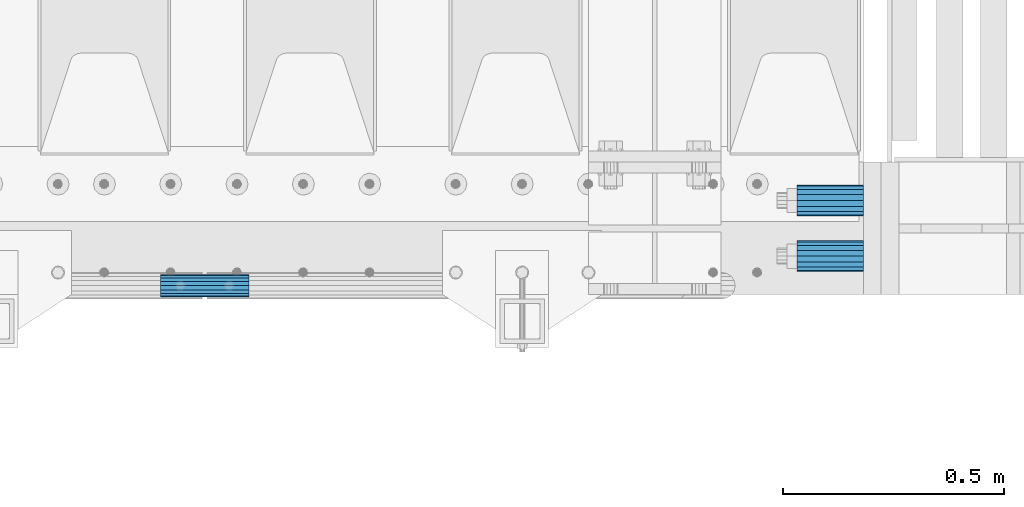
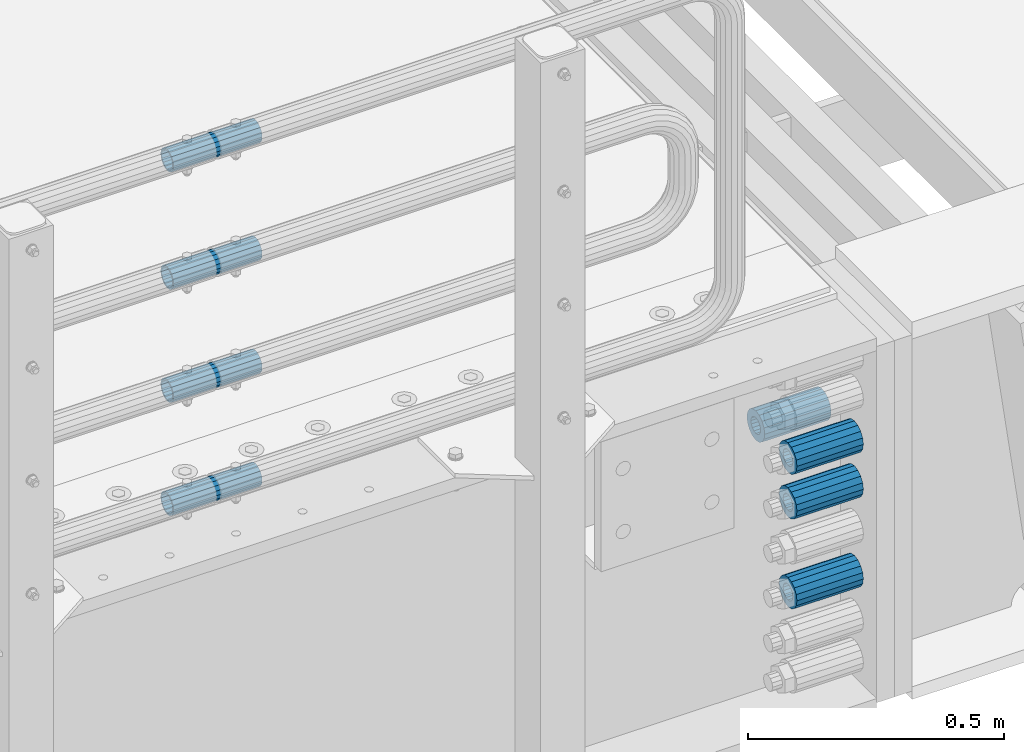
# One storey, part 157 of 247: 8 beams.
"""IFC2X3 building model written with IfcOpenShell, lengths in millimetres."""

from ifc_helpers import new_model, si_unit, frame, origin_with_axes, place, context, subcontext, project, spatial, faceted_brep, material, type_object, element, save


model = new_model("IFC2X3")

# Units and contexts
model_context = context("Model", 3, precision=1e-05, world=origin_with_axes())
body_context = subcontext(model_context, "Body", "Model", "MODEL_VIEW")
ifc_project = project(units=[si_unit("LENGTHUNIT", "METRE", prefix="MILLI"), si_unit("AREAUNIT", "SQUARE_METRE"), si_unit("VOLUMEUNIT", "CUBIC_METRE"), si_unit("MASSUNIT", "GRAM", prefix="KILO"), si_unit("TIMEUNIT", "SECOND"), si_unit("PLANEANGLEUNIT", "RADIAN"), si_unit("SOLIDANGLEUNIT", "STERADIAN"), si_unit("THERMODYNAMICTEMPERATUREUNIT", "DEGREE_CELSIUS"), si_unit("LUMINOUSINTENSITYUNIT", "LUMEN")], contexts=[model_context])

# Site, building, storey
site_placement = place(None, origin_with_axes())
site = spatial("IfcSite", under=ifc_project, at=site_placement, CompositionType="ELEMENT")
building_placement = place(site_placement, origin_with_axes())
building = spatial("IfcBuilding", under=site, at=building_placement, Name="Standard", CompositionType="ELEMENT")
storey_placement = place(building_placement, origin_with_axes())
storey = spatial("IfcBuildingStorey", under=building, at=storey_placement, Name="Undefined", CompositionType="ELEMENT", Elevation=0.0)

# Beams
ifc_material = material()
beam_type_1 = type_object("IfcBeamType", PredefinedType="NOTDEFINED")
beam_1_placement = place(storey_placement, frame((16667.0, 63.0, -285.0), z_axis=(0.0, 0.0, 1.0), x_axis=(1.0, 0.0, 0.0)))
element("IfcBeam", 1, at=beam_1_placement, inside=storey, type_object=beam_type_1, material=ifc_material, context=body_context, shape_type="Brep", body=[
    faceted_brep([(-1.3120632047503e-07, -18.9999999995497, -6.27005647402257e-09), (0.0, -17.5537111177146, 7.27098521493672), (150.0, -17.5537111177146, 7.27098521493672), (150.0, -19.0, 0.0), (0.0, -13.4350288425444, 13.4350288425444), (150.0, -13.4350288425444, 13.4350288425444), (0.0, -7.2709852149369, 17.5537111177144), (150.0, -7.2709852149369, 17.5537111177144), (-6.3396328187082e-09, 4.50427251053043e-10, 18.9999999937299), (150.0, 0.0, 19.0), (0.0, 7.2709852149369, 17.5537111177144), (150.0, 7.2709852149369, 17.5537111177144), (0.0, 13.4350288425444, 13.4350288425444), (150.0, 13.4350288425444, 13.4350288425444), (0.0, 17.5537111177146, 7.2709852149367), (150.0, 17.5537111177146, 7.2709852149367), (1.33208573060983e-07, 19.0000000004504, -6.27005647402257e-09), (150.0, 19.0, 0.0), (0.0, 17.5537111177146, -7.2709852149367), (150.0, 17.5537111177146, -7.2709852149367), (0.0, 13.4350288425444, -13.4350288425444), (150.0, 13.4350288425444, -13.4350288425444), (0.0, 7.2709852149369, -17.5537111177144), (150.0, 7.2709852149369, -17.5537111177144), (8.3418854046613e-09, 4.50427251053043e-10, -19.0000000062682), (150.0, 0.0, -19.0), (0.0, -7.2709852149369, -17.5537111177144), (150.0, -7.2709852149369, -17.5537111177144), (0.0, -13.4350288425444, -13.4350288425444), (150.0, -13.4350288425444, -13.4350288425444), (0.0, -17.5537111177146, -7.2709852149367), (150.0, -17.5537111177146, -7.2709852149367), (0.0, -35.0, 0.0), (0.0, -32.335783637895, -13.3939201327782), (150.0, -32.335783637895, -13.3939201327782), (150.0, -35.0, 0.0), (0.0, -24.7487373415292, -24.7487373415291), (150.0, -24.7487373415293, -24.7487373415292), (0.0, -13.3939201327781, -32.335783637895), (150.0, -13.393920132778, -32.335783637895), (0.0, 0.0, -35.0000000000001), (150.0, 0.0, -35.0), (0.0, 13.3939201327782, -32.335783637895), (150.0, 13.393920132778, -32.335783637895), (0.0, 24.7487373415292, -24.7487373415291), (150.0, 24.7487373415293, -24.7487373415292), (0.0, 32.335783637895, -13.3939201327782), (150.0, 32.335783637895, -13.3939201327781), (0.0, 35.0, 0.0), (150.0, 35.0, 0.0), (0.0, 32.335783637895, 13.3939201327781), (150.0, 32.335783637895, 13.3939201327781), (0.0, 24.7487373415292, 24.748737341529), (150.0, 24.7487373415293, 24.7487373415292), (0.0, 13.3939201327781, 32.335783637895), (150.0, 13.393920132778, 32.335783637895), (0.0, 0.0, 35.0), (150.0, 0.0, 35.0), (0.0, -13.3939201327781, 32.335783637895), (150.0, -13.393920132778, 32.335783637895), (0.0, -24.7487373415292, 24.748737341529), (150.0, -24.7487373415293, 24.7487373415292), (0.0, -32.335783637895, 13.3939201327781), (150.0, -32.335783637895, 13.3939201327781)], [[[0, 1, 2, 3]], [[1, 4, 5, 2]], [[4, 6, 7, 5]], [[6, 8, 9, 7]], [[8, 10, 11, 9]], [[10, 12, 13, 11]], [[12, 14, 15, 13]], [[14, 16, 17, 15]], [[16, 18, 19, 17]], [[18, 20, 21, 19]], [[20, 22, 23, 21]], [[22, 24, 25, 23]], [[24, 26, 27, 25]], [[26, 28, 29, 27]], [[28, 30, 31, 29]], [[30, 0, 3, 31]], [[32, 33, 34, 35]], [[33, 36, 37, 34]], [[36, 38, 39, 37]], [[38, 40, 41, 39]], [[40, 42, 43, 41]], [[42, 44, 45, 43]], [[44, 46, 47, 45]], [[46, 48, 49, 47]], [[48, 50, 51, 49]], [[50, 52, 53, 51]], [[52, 54, 55, 53]], [[54, 56, 57, 55]], [[56, 58, 59, 57]], [[58, 60, 61, 59]], [[60, 62, 63, 61]], [[62, 32, 35, 63]], [[37, 39, 41, 43, 45, 47, 49, 51, 53, 55, 57, 59, 61, 63, 35, 34], [5, 7, 9, 11, 13, 15, 17, 19, 21, 23, 25, 27, 29, 31, 3, 2]], [[62, 60, 58, 56, 54, 52, 50, 48, 46, 44, 42, 40, 38, 36, 33, 32], [30, 28, 26, 24, 22, 20, 18, 16, 14, 12, 10, 8, 6, 4, 1, 0]]]),
])
beam_2_placement = place(storey_placement, frame((16667.0, -63.0, -392.0), z_axis=(0.0, 0.0, 1.0), x_axis=(1.0, 0.0, 0.0)))
element("IfcBeam", 2, at=beam_2_placement, inside=storey, type_object=beam_type_1, material=ifc_material, context=body_context, shape_type="Brep", body=[
    faceted_brep([(-1.3120632047503e-07, -18.9999999995497, -6.27005647402257e-09), (0.0, -17.5537111177146, 7.27098521493672), (150.0, -17.5537111177146, 7.27098521493672), (150.0, -19.0, 0.0), (0.0, -13.4350288425444, 13.4350288425444), (150.0, -13.4350288425444, 13.4350288425444), (0.0, -7.2709852149369, 17.5537111177144), (150.0, -7.2709852149369, 17.5537111177144), (-6.3396328187082e-09, 4.50427251053043e-10, 18.9999999937299), (150.0, 0.0, 19.0), (0.0, 7.2709852149369, 17.5537111177144), (150.0, 7.2709852149369, 17.5537111177144), (0.0, 13.4350288425444, 13.4350288425444), (150.0, 13.4350288425444, 13.4350288425444), (0.0, 17.5537111177146, 7.2709852149367), (150.0, 17.5537111177146, 7.2709852149367), (1.33208573060983e-07, 19.0000000004504, -6.27005647402257e-09), (150.0, 19.0, 0.0), (0.0, 17.5537111177146, -7.2709852149367), (150.0, 17.5537111177146, -7.2709852149367), (0.0, 13.4350288425444, -13.4350288425444), (150.0, 13.4350288425444, -13.4350288425444), (0.0, 7.2709852149369, -17.5537111177144), (150.0, 7.2709852149369, -17.5537111177144), (8.3418854046613e-09, 4.50427251053043e-10, -19.0000000062682), (150.0, 0.0, -19.0), (0.0, -7.2709852149369, -17.5537111177144), (150.0, -7.2709852149369, -17.5537111177144), (0.0, -13.4350288425444, -13.4350288425444), (150.0, -13.4350288425444, -13.4350288425444), (0.0, -17.5537111177146, -7.2709852149367), (150.0, -17.5537111177146, -7.2709852149367), (0.0, -35.0, 0.0), (0.0, -32.335783637895, -13.3939201327782), (150.0, -32.335783637895, -13.3939201327782), (150.0, -35.0, 0.0), (0.0, -24.7487373415292, -24.7487373415291), (150.0, -24.7487373415293, -24.7487373415292), (0.0, -13.3939201327781, -32.335783637895), (150.0, -13.393920132778, -32.335783637895), (0.0, 0.0, -35.0000000000001), (150.0, 0.0, -35.0), (0.0, 13.3939201327782, -32.335783637895), (150.0, 13.393920132778, -32.335783637895), (0.0, 24.7487373415292, -24.7487373415291), (150.0, 24.7487373415293, -24.7487373415292), (0.0, 32.335783637895, -13.3939201327782), (150.0, 32.335783637895, -13.3939201327781), (0.0, 35.0, 0.0), (150.0, 35.0, 0.0), (0.0, 32.335783637895, 13.3939201327781), (150.0, 32.335783637895, 13.3939201327781), (0.0, 24.7487373415292, 24.748737341529), (150.0, 24.7487373415293, 24.7487373415292), (0.0, 13.3939201327781, 32.335783637895), (150.0, 13.393920132778, 32.335783637895), (0.0, 0.0, 35.0), (150.0, 0.0, 35.0), (0.0, -13.3939201327781, 32.335783637895), (150.0, -13.393920132778, 32.335783637895), (0.0, -24.7487373415292, 24.748737341529), (150.0, -24.7487373415293, 24.7487373415292), (0.0, -32.335783637895, 13.3939201327781), (150.0, -32.335783637895, 13.3939201327781)], [[[0, 1, 2, 3]], [[1, 4, 5, 2]], [[4, 6, 7, 5]], [[6, 8, 9, 7]], [[8, 10, 11, 9]], [[10, 12, 13, 11]], [[12, 14, 15, 13]], [[14, 16, 17, 15]], [[16, 18, 19, 17]], [[18, 20, 21, 19]], [[20, 22, 23, 21]], [[22, 24, 25, 23]], [[24, 26, 27, 25]], [[26, 28, 29, 27]], [[28, 30, 31, 29]], [[30, 0, 3, 31]], [[32, 33, 34, 35]], [[33, 36, 37, 34]], [[36, 38, 39, 37]], [[38, 40, 41, 39]], [[40, 42, 43, 41]], [[42, 44, 45, 43]], [[44, 46, 47, 45]], [[46, 48, 49, 47]], [[48, 50, 51, 49]], [[50, 52, 53, 51]], [[52, 54, 55, 53]], [[54, 56, 57, 55]], [[56, 58, 59, 57]], [[58, 60, 61, 59]], [[60, 62, 63, 61]], [[62, 32, 35, 63]], [[37, 39, 41, 43, 45, 47, 49, 51, 53, 55, 57, 59, 61, 63, 35, 34], [5, 7, 9, 11, 13, 15, 17, 19, 21, 23, 25, 27, 29, 31, 3, 2]], [[62, 60, 58, 56, 54, 52, 50, 48, 46, 44, 42, 40, 38, 36, 33, 32], [30, 28, 26, 24, 22, 20, 18, 16, 14, 12, 10, 8, 6, 4, 1, 0]]]),
])
beam_3_placement = place(storey_placement, frame((16667.0, -63.0, -606.0), z_axis=(0.0, 0.0, 1.0), x_axis=(1.0, 0.0, 0.0)))
element("IfcBeam", 3, at=beam_3_placement, inside=storey, type_object=beam_type_1, material=ifc_material, context=body_context, shape_type="Brep", body=[
    faceted_brep([(-1.3120632047503e-07, -18.9999999995497, -6.27005647402257e-09), (0.0, -17.5537111177146, 7.27098521493672), (150.0, -17.5537111177146, 7.27098521493672), (150.0, -19.0, 0.0), (0.0, -13.4350288425444, 13.4350288425444), (150.0, -13.4350288425444, 13.4350288425444), (0.0, -7.2709852149369, 17.5537111177144), (150.0, -7.2709852149369, 17.5537111177144), (-6.3396328187082e-09, 4.50427251053043e-10, 18.9999999937299), (150.0, 0.0, 19.0), (0.0, 7.2709852149369, 17.5537111177144), (150.0, 7.2709852149369, 17.5537111177144), (0.0, 13.4350288425444, 13.4350288425444), (150.0, 13.4350288425444, 13.4350288425444), (0.0, 17.5537111177146, 7.2709852149367), (150.0, 17.5537111177146, 7.2709852149367), (1.33208573060983e-07, 19.0000000004504, -6.27005647402257e-09), (150.0, 19.0, 0.0), (0.0, 17.5537111177146, -7.2709852149367), (150.0, 17.5537111177146, -7.2709852149367), (0.0, 13.4350288425444, -13.4350288425444), (150.0, 13.4350288425444, -13.4350288425444), (0.0, 7.2709852149369, -17.5537111177144), (150.0, 7.2709852149369, -17.5537111177144), (8.3418854046613e-09, 4.50427251053043e-10, -19.0000000062682), (150.0, 0.0, -19.0), (0.0, -7.2709852149369, -17.5537111177144), (150.0, -7.2709852149369, -17.5537111177144), (0.0, -13.4350288425444, -13.4350288425444), (150.0, -13.4350288425444, -13.4350288425444), (0.0, -17.5537111177146, -7.2709852149367), (150.0, -17.5537111177146, -7.2709852149367), (0.0, -35.0, 0.0), (0.0, -32.335783637895, -13.3939201327782), (150.0, -32.335783637895, -13.3939201327782), (150.0, -35.0, 0.0), (0.0, -24.7487373415292, -24.7487373415291), (150.0, -24.7487373415293, -24.7487373415292), (0.0, -13.3939201327781, -32.335783637895), (150.0, -13.393920132778, -32.335783637895), (0.0, 0.0, -35.0000000000001), (150.0, 0.0, -35.0), (0.0, 13.3939201327782, -32.335783637895), (150.0, 13.393920132778, -32.335783637895), (0.0, 24.7487373415292, -24.7487373415291), (150.0, 24.7487373415293, -24.7487373415292), (0.0, 32.335783637895, -13.3939201327782), (150.0, 32.335783637895, -13.3939201327781), (0.0, 35.0, 0.0), (150.0, 35.0, 0.0), (0.0, 32.335783637895, 13.3939201327781), (150.0, 32.335783637895, 13.3939201327781), (0.0, 24.7487373415292, 24.748737341529), (150.0, 24.7487373415293, 24.7487373415292), (0.0, 13.3939201327781, 32.335783637895), (150.0, 13.393920132778, 32.335783637895), (0.0, 0.0, 35.0), (150.0, 0.0, 35.0), (0.0, -13.3939201327781, 32.335783637895), (150.0, -13.393920132778, 32.335783637895), (0.0, -24.7487373415292, 24.748737341529), (150.0, -24.7487373415293, 24.7487373415292), (0.0, -32.335783637895, 13.3939201327781), (150.0, -32.335783637895, 13.3939201327781)], [[[0, 1, 2, 3]], [[1, 4, 5, 2]], [[4, 6, 7, 5]], [[6, 8, 9, 7]], [[8, 10, 11, 9]], [[10, 12, 13, 11]], [[12, 14, 15, 13]], [[14, 16, 17, 15]], [[16, 18, 19, 17]], [[18, 20, 21, 19]], [[20, 22, 23, 21]], [[22, 24, 25, 23]], [[24, 26, 27, 25]], [[26, 28, 29, 27]], [[28, 30, 31, 29]], [[30, 0, 3, 31]], [[32, 33, 34, 35]], [[33, 36, 37, 34]], [[36, 38, 39, 37]], [[38, 40, 41, 39]], [[40, 42, 43, 41]], [[42, 44, 45, 43]], [[44, 46, 47, 45]], [[46, 48, 49, 47]], [[48, 50, 51, 49]], [[50, 52, 53, 51]], [[52, 54, 55, 53]], [[54, 56, 57, 55]], [[56, 58, 59, 57]], [[58, 60, 61, 59]], [[60, 62, 63, 61]], [[62, 32, 35, 63]], [[37, 39, 41, 43, 45, 47, 49, 51, 53, 55, 57, 59, 61, 63, 35, 34], [5, 7, 9, 11, 13, 15, 17, 19, 21, 23, 25, 27, 29, 31, 3, 2]], [[62, 60, 58, 56, 54, 52, 50, 48, 46, 44, 42, 40, 38, 36, 33, 32], [30, 28, 26, 24, 22, 20, 18, 16, 14, 12, 10, 8, 6, 4, 1, 0]]]),
])
beam_4_placement = place(storey_placement, frame((16667.0, -63.0, -285.0), z_axis=(0.0, 0.0, 1.0), x_axis=(1.0, 0.0, 0.0)))
element("IfcBeam", 4, at=beam_4_placement, inside=storey, type_object=beam_type_1, material=ifc_material, context=body_context, shape_type="Brep", body=[
    faceted_brep([(-1.3120632047503e-07, -18.9999999995497, -6.27005647402257e-09), (0.0, -17.5537111177146, 7.27098521493672), (150.0, -17.5537111177146, 7.27098521493672), (150.0, -19.0, 0.0), (0.0, -13.4350288425444, 13.4350288425444), (150.0, -13.4350288425444, 13.4350288425444), (0.0, -7.2709852149369, 17.5537111177144), (150.0, -7.2709852149369, 17.5537111177144), (-6.3396328187082e-09, 4.50427251053043e-10, 18.9999999937299), (150.0, 0.0, 19.0), (0.0, 7.2709852149369, 17.5537111177144), (150.0, 7.2709852149369, 17.5537111177144), (0.0, 13.4350288425444, 13.4350288425444), (150.0, 13.4350288425444, 13.4350288425444), (0.0, 17.5537111177146, 7.2709852149367), (150.0, 17.5537111177146, 7.2709852149367), (1.33208573060983e-07, 19.0000000004504, -6.27005647402257e-09), (150.0, 19.0, 0.0), (0.0, 17.5537111177146, -7.2709852149367), (150.0, 17.5537111177146, -7.2709852149367), (0.0, 13.4350288425444, -13.4350288425444), (150.0, 13.4350288425444, -13.4350288425444), (0.0, 7.2709852149369, -17.5537111177144), (150.0, 7.2709852149369, -17.5537111177144), (8.3418854046613e-09, 4.50427251053043e-10, -19.0000000062682), (150.0, 0.0, -19.0), (0.0, -7.2709852149369, -17.5537111177144), (150.0, -7.2709852149369, -17.5537111177144), (0.0, -13.4350288425444, -13.4350288425444), (150.0, -13.4350288425444, -13.4350288425444), (0.0, -17.5537111177146, -7.2709852149367), (150.0, -17.5537111177146, -7.2709852149367), (0.0, -35.0, 0.0), (0.0, -32.335783637895, -13.3939201327782), (150.0, -32.335783637895, -13.3939201327782), (150.0, -35.0, 0.0), (0.0, -24.7487373415292, -24.7487373415291), (150.0, -24.7487373415293, -24.7487373415292), (0.0, -13.3939201327781, -32.335783637895), (150.0, -13.393920132778, -32.335783637895), (0.0, 0.0, -35.0000000000001), (150.0, 0.0, -35.0), (0.0, 13.3939201327782, -32.335783637895), (150.0, 13.393920132778, -32.335783637895), (0.0, 24.7487373415292, -24.7487373415291), (150.0, 24.7487373415293, -24.7487373415292), (0.0, 32.335783637895, -13.3939201327782), (150.0, 32.335783637895, -13.3939201327781), (0.0, 35.0, 0.0), (150.0, 35.0, 0.0), (0.0, 32.335783637895, 13.3939201327781), (150.0, 32.335783637895, 13.3939201327781), (0.0, 24.7487373415292, 24.748737341529), (150.0, 24.7487373415293, 24.7487373415292), (0.0, 13.3939201327781, 32.335783637895), (150.0, 13.393920132778, 32.335783637895), (0.0, 0.0, 35.0), (150.0, 0.0, 35.0), (0.0, -13.3939201327781, 32.335783637895), (150.0, -13.393920132778, 32.335783637895), (0.0, -24.7487373415292, 24.748737341529), (150.0, -24.7487373415293, 24.7487373415292), (0.0, -32.335783637895, 13.3939201327781), (150.0, -32.335783637895, 13.3939201327781)], [[[0, 1, 2, 3]], [[1, 4, 5, 2]], [[4, 6, 7, 5]], [[6, 8, 9, 7]], [[8, 10, 11, 9]], [[10, 12, 13, 11]], [[12, 14, 15, 13]], [[14, 16, 17, 15]], [[16, 18, 19, 17]], [[18, 20, 21, 19]], [[20, 22, 23, 21]], [[22, 24, 25, 23]], [[24, 26, 27, 25]], [[26, 28, 29, 27]], [[28, 30, 31, 29]], [[30, 0, 3, 31]], [[32, 33, 34, 35]], [[33, 36, 37, 34]], [[36, 38, 39, 37]], [[38, 40, 41, 39]], [[40, 42, 43, 41]], [[42, 44, 45, 43]], [[44, 46, 47, 45]], [[46, 48, 49, 47]], [[48, 50, 51, 49]], [[50, 52, 53, 51]], [[52, 54, 55, 53]], [[54, 56, 57, 55]], [[56, 58, 59, 57]], [[58, 60, 61, 59]], [[60, 62, 63, 61]], [[62, 32, 35, 63]], [[37, 39, 41, 43, 45, 47, 49, 51, 53, 55, 57, 59, 61, 63, 35, 34], [5, 7, 9, 11, 13, 15, 17, 19, 21, 23, 25, 27, 29, 31, 3, 2]], [[62, 60, 58, 56, 54, 52, 50, 48, 46, 44, 42, 40, 38, 36, 33, 32], [30, 28, 26, 24, 22, 20, 18, 16, 14, 12, 10, 8, 6, 4, 1, 0]]]),
])
beam_type_2 = type_object("IfcBeamType", PredefinedType="NOTDEFINED")
beam_5_placement = place(storey_placement, frame((15226.9975029999, -129.849999999603, 419.849999999725), z_axis=(0.0, 0.0, 1.0), x_axis=(1.0, 0.0, 0.0)))
element("IfcBeam", 5, at=beam_5_placement, inside=storey, type_object=beam_type_2, material=ifc_material, context=body_context, shape_type="Brep", body=[
    faceted_brep([(0.0, -21.8999999999996, 0.0), (0.0, -20.232961761998, 8.38076716879547), (200.0, -20.232961761998, 8.38076716879547), (200.0, -21.8999999999996, 0.0), (0.0, -15.4856385079856, 15.4856385079854), (200.0, -15.4856385079856, 15.4856385079854), (0.0, -8.3807671687955, 20.2329617619972), (200.0, -8.3807671687955, 20.2329617619972), (0.0, 0.0, 21.9), (200.0, 0.0, 21.9), (0.0, 8.3807671687955, 20.2329617619972), (200.0, 8.3807671687955, 20.2329617619972), (0.0, 15.4856385079856, 15.4856385079854), (200.0, 15.4856385079856, 15.4856385079854), (0.0, 20.232961761998, 8.38076716879547), (200.0, 20.232961761998, 8.38076716879547), (0.0, 21.8999999999996, 0.0), (200.0, 21.8999999999996, 0.0), (0.0, 20.232961761998, -8.38076716879547), (200.0, 20.232961761998, -8.38076716879547), (0.0, 15.4856385079856, -15.4856385079854), (200.0, 15.4856385079856, -15.4856385079854), (0.0, 8.3807671687955, -20.2329617619972), (200.0, 8.3807671687955, -20.2329617619972), (0.0, 0.0, -21.9), (200.0, 0.0, -21.9), (0.0, -8.3807671687955, -20.2329617619972), (200.0, -8.3807671687955, -20.2329617619972), (0.0, -15.4856385079856, -15.4856385079854), (200.0, -15.4856385079856, -15.4856385079854), (0.0, -20.232961761998, -8.38076716879547), (200.0, -20.232961761998, -8.38076716879547), (0.0, -25.5, 0.0), (0.0, -23.5589280790373, -9.7584275253098), (200.0, -23.5589280790373, -9.7584275253098), (200.0, -25.5, 0.0), (0.0, -18.0312229202573, -18.031222920257), (200.0, -18.0312229202573, -18.031222920257), (0.0, -9.75842752531025, -23.5589280790378), (200.0, -9.75842752531025, -23.5589280790378), (0.0, 0.0, -25.5), (200.0, 0.0, -25.5), (0.0, 9.75842752531025, -23.5589280790378), (200.0, 9.75842752531025, -23.5589280790378), (0.0, 18.0312229202573, -18.031222920257), (200.0, 18.0312229202573, -18.031222920257), (0.0, 23.5589280790373, -9.7584275253098), (200.0, 23.5589280790373, -9.7584275253098), (0.0, 25.5, 0.0), (200.0, 25.5, 0.0), (0.0, 23.5589280790373, 9.7584275253098), (200.0, 23.5589280790373, 9.7584275253098), (0.0, 18.0312229202573, 18.031222920257), (200.0, 18.0312229202573, 18.031222920257), (0.0, 9.75842752531025, 23.5589280790378), (200.0, 9.75842752531025, 23.5589280790378), (0.0, 0.0, 25.5), (200.0, 0.0, 25.5), (0.0, -9.75842752531025, 23.5589280790378), (200.0, -9.75842752531025, 23.5589280790378), (0.0, -18.0312229202573, 18.031222920257), (200.0, -18.0312229202573, 18.031222920257), (0.0, -23.5589280790373, 9.7584275253098), (200.0, -23.5589280790373, 9.7584275253098)], [[[0, 1, 2, 3]], [[1, 4, 5, 2]], [[4, 6, 7, 5]], [[6, 8, 9, 7]], [[8, 10, 11, 9]], [[10, 12, 13, 11]], [[12, 14, 15, 13]], [[14, 16, 17, 15]], [[16, 18, 19, 17]], [[18, 20, 21, 19]], [[20, 22, 23, 21]], [[22, 24, 25, 23]], [[24, 26, 27, 25]], [[26, 28, 29, 27]], [[28, 30, 31, 29]], [[30, 0, 3, 31]], [[32, 33, 34, 35]], [[33, 36, 37, 34]], [[36, 38, 39, 37]], [[38, 40, 41, 39]], [[40, 42, 43, 41]], [[42, 44, 45, 43]], [[44, 46, 47, 45]], [[46, 48, 49, 47]], [[48, 50, 51, 49]], [[50, 52, 53, 51]], [[52, 54, 55, 53]], [[54, 56, 57, 55]], [[56, 58, 59, 57]], [[58, 60, 61, 59]], [[60, 62, 63, 61]], [[62, 32, 35, 63]], [[37, 39, 41, 43, 45, 47, 49, 51, 53, 55, 57, 59, 61, 63, 35, 34], [5, 7, 9, 11, 13, 15, 17, 19, 21, 23, 25, 27, 29, 31, 3, 2]], [[62, 60, 58, 56, 54, 52, 50, 48, 46, 44, 42, 40, 38, 36, 33, 32], [30, 28, 26, 24, 22, 20, 18, 16, 14, 12, 10, 8, 6, 4, 1, 0]]]),
])
beam_6_placement = place(storey_placement, frame((15226.9975029999, -129.849999999603, 149.849999999725), z_axis=(0.0, 0.0, 1.0), x_axis=(1.0, 0.0, 0.0)))
element("IfcBeam", 6, at=beam_6_placement, inside=storey, type_object=beam_type_2, material=ifc_material, context=body_context, shape_type="Brep", body=[
    faceted_brep([(0.0, -21.8999999999996, 0.0), (0.0, -20.232961761998, 8.38076716879547), (200.0, -20.232961761998, 8.38076716879547), (200.0, -21.8999999999996, 0.0), (0.0, -15.4856385079856, 15.4856385079854), (200.0, -15.4856385079856, 15.4856385079854), (0.0, -8.3807671687955, 20.2329617619972), (200.0, -8.3807671687955, 20.2329617619972), (0.0, 0.0, 21.9), (200.0, 0.0, 21.9), (0.0, 8.3807671687955, 20.2329617619972), (200.0, 8.3807671687955, 20.2329617619972), (0.0, 15.4856385079856, 15.4856385079854), (200.0, 15.4856385079856, 15.4856385079854), (0.0, 20.232961761998, 8.38076716879547), (200.0, 20.232961761998, 8.38076716879547), (0.0, 21.8999999999996, 0.0), (200.0, 21.8999999999996, 0.0), (0.0, 20.232961761998, -8.38076716879547), (200.0, 20.232961761998, -8.38076716879547), (0.0, 15.4856385079856, -15.4856385079854), (200.0, 15.4856385079856, -15.4856385079854), (0.0, 8.3807671687955, -20.2329617619972), (200.0, 8.3807671687955, -20.2329617619972), (0.0, 0.0, -21.9), (200.0, 0.0, -21.9), (0.0, -8.3807671687955, -20.2329617619972), (200.0, -8.3807671687955, -20.2329617619972), (0.0, -15.4856385079856, -15.4856385079854), (200.0, -15.4856385079856, -15.4856385079854), (0.0, -20.232961761998, -8.38076716879547), (200.0, -20.232961761998, -8.38076716879547), (0.0, -25.5, 0.0), (0.0, -23.5589280790373, -9.7584275253098), (200.0, -23.5589280790373, -9.7584275253098), (200.0, -25.5, 0.0), (0.0, -18.0312229202573, -18.031222920257), (200.0, -18.0312229202573, -18.031222920257), (0.0, -9.75842752531025, -23.5589280790378), (200.0, -9.75842752531025, -23.5589280790378), (0.0, 0.0, -25.5), (200.0, 0.0, -25.5), (0.0, 9.75842752531025, -23.5589280790378), (200.0, 9.75842752531025, -23.5589280790378), (0.0, 18.0312229202573, -18.031222920257), (200.0, 18.0312229202573, -18.031222920257), (0.0, 23.5589280790373, -9.7584275253098), (200.0, 23.5589280790373, -9.7584275253098), (0.0, 25.5, 0.0), (200.0, 25.5, 0.0), (0.0, 23.5589280790373, 9.7584275253098), (200.0, 23.5589280790373, 9.7584275253098), (0.0, 18.0312229202573, 18.031222920257), (200.0, 18.0312229202573, 18.031222920257), (0.0, 9.75842752531025, 23.5589280790378), (200.0, 9.75842752531025, 23.5589280790378), (0.0, 0.0, 25.5), (200.0, 0.0, 25.5), (0.0, -9.75842752531025, 23.5589280790378), (200.0, -9.75842752531025, 23.5589280790378), (0.0, -18.0312229202573, 18.031222920257), (200.0, -18.0312229202573, 18.031222920257), (0.0, -23.5589280790373, 9.7584275253098), (200.0, -23.5589280790373, 9.7584275253098)], [[[0, 1, 2, 3]], [[1, 4, 5, 2]], [[4, 6, 7, 5]], [[6, 8, 9, 7]], [[8, 10, 11, 9]], [[10, 12, 13, 11]], [[12, 14, 15, 13]], [[14, 16, 17, 15]], [[16, 18, 19, 17]], [[18, 20, 21, 19]], [[20, 22, 23, 21]], [[22, 24, 25, 23]], [[24, 26, 27, 25]], [[26, 28, 29, 27]], [[28, 30, 31, 29]], [[30, 0, 3, 31]], [[32, 33, 34, 35]], [[33, 36, 37, 34]], [[36, 38, 39, 37]], [[38, 40, 41, 39]], [[40, 42, 43, 41]], [[42, 44, 45, 43]], [[44, 46, 47, 45]], [[46, 48, 49, 47]], [[48, 50, 51, 49]], [[50, 52, 53, 51]], [[52, 54, 55, 53]], [[54, 56, 57, 55]], [[56, 58, 59, 57]], [[58, 60, 61, 59]], [[60, 62, 63, 61]], [[62, 32, 35, 63]], [[37, 39, 41, 43, 45, 47, 49, 51, 53, 55, 57, 59, 61, 63, 35, 34], [5, 7, 9, 11, 13, 15, 17, 19, 21, 23, 25, 27, 29, 31, 3, 2]], [[62, 60, 58, 56, 54, 52, 50, 48, 46, 44, 42, 40, 38, 36, 33, 32], [30, 28, 26, 24, 22, 20, 18, 16, 14, 12, 10, 8, 6, 4, 1, 0]]]),
])
beam_7_placement = place(storey_placement, frame((15226.9975029999, -129.849999999603, 689.849999999725), z_axis=(0.0, 0.0, 1.0), x_axis=(1.0, 0.0, 0.0)))
element("IfcBeam", 7, at=beam_7_placement, inside=storey, type_object=beam_type_2, material=ifc_material, context=body_context, shape_type="Brep", body=[
    faceted_brep([(0.0, -21.8999999999996, 0.0), (0.0, -20.232961761998, 8.38076716879547), (200.0, -20.232961761998, 8.38076716879547), (200.0, -21.8999999999996, 0.0), (0.0, -15.4856385079856, 15.4856385079854), (200.0, -15.4856385079856, 15.4856385079854), (0.0, -8.3807671687955, 20.2329617619972), (200.0, -8.3807671687955, 20.2329617619972), (0.0, 0.0, 21.9), (200.0, 0.0, 21.9), (0.0, 8.3807671687955, 20.2329617619972), (200.0, 8.3807671687955, 20.2329617619972), (0.0, 15.4856385079856, 15.4856385079854), (200.0, 15.4856385079856, 15.4856385079854), (0.0, 20.232961761998, 8.38076716879547), (200.0, 20.232961761998, 8.38076716879547), (0.0, 21.8999999999996, 0.0), (200.0, 21.8999999999996, 0.0), (0.0, 20.232961761998, -8.38076716879547), (200.0, 20.232961761998, -8.38076716879547), (0.0, 15.4856385079856, -15.4856385079854), (200.0, 15.4856385079856, -15.4856385079854), (0.0, 8.3807671687955, -20.2329617619972), (200.0, 8.3807671687955, -20.2329617619972), (0.0, 0.0, -21.9), (200.0, 0.0, -21.9), (0.0, -8.3807671687955, -20.2329617619972), (200.0, -8.3807671687955, -20.2329617619972), (0.0, -15.4856385079856, -15.4856385079854), (200.0, -15.4856385079856, -15.4856385079854), (0.0, -20.232961761998, -8.38076716879547), (200.0, -20.232961761998, -8.38076716879547), (0.0, -25.5, 0.0), (0.0, -23.5589280790373, -9.7584275253098), (200.0, -23.5589280790373, -9.7584275253098), (200.0, -25.5, 0.0), (0.0, -18.0312229202573, -18.031222920257), (200.0, -18.0312229202573, -18.031222920257), (0.0, -9.75842752531025, -23.5589280790378), (200.0, -9.75842752531025, -23.5589280790378), (0.0, 0.0, -25.5), (200.0, 0.0, -25.5), (0.0, 9.75842752531025, -23.5589280790378), (200.0, 9.75842752531025, -23.5589280790378), (0.0, 18.0312229202573, -18.031222920257), (200.0, 18.0312229202573, -18.031222920257), (0.0, 23.5589280790373, -9.7584275253098), (200.0, 23.5589280790373, -9.7584275253098), (0.0, 25.5, 0.0), (200.0, 25.5, 0.0), (0.0, 23.5589280790373, 9.7584275253098), (200.0, 23.5589280790373, 9.7584275253098), (0.0, 18.0312229202573, 18.031222920257), (200.0, 18.0312229202573, 18.031222920257), (0.0, 9.75842752531025, 23.5589280790378), (200.0, 9.75842752531025, 23.5589280790378), (0.0, 0.0, 25.5), (200.0, 0.0, 25.5), (0.0, -9.75842752531025, 23.5589280790378), (200.0, -9.75842752531025, 23.5589280790378), (0.0, -18.0312229202573, 18.031222920257), (200.0, -18.0312229202573, 18.031222920257), (0.0, -23.5589280790373, 9.7584275253098), (200.0, -23.5589280790373, 9.7584275253098)], [[[0, 1, 2, 3]], [[1, 4, 5, 2]], [[4, 6, 7, 5]], [[6, 8, 9, 7]], [[8, 10, 11, 9]], [[10, 12, 13, 11]], [[12, 14, 15, 13]], [[14, 16, 17, 15]], [[16, 18, 19, 17]], [[18, 20, 21, 19]], [[20, 22, 23, 21]], [[22, 24, 25, 23]], [[24, 26, 27, 25]], [[26, 28, 29, 27]], [[28, 30, 31, 29]], [[30, 0, 3, 31]], [[32, 33, 34, 35]], [[33, 36, 37, 34]], [[36, 38, 39, 37]], [[38, 40, 41, 39]], [[40, 42, 43, 41]], [[42, 44, 45, 43]], [[44, 46, 47, 45]], [[46, 48, 49, 47]], [[48, 50, 51, 49]], [[50, 52, 53, 51]], [[52, 54, 55, 53]], [[54, 56, 57, 55]], [[56, 58, 59, 57]], [[58, 60, 61, 59]], [[60, 62, 63, 61]], [[62, 32, 35, 63]], [[37, 39, 41, 43, 45, 47, 49, 51, 53, 55, 57, 59, 61, 63, 35, 34], [5, 7, 9, 11, 13, 15, 17, 19, 21, 23, 25, 27, 29, 31, 3, 2]], [[62, 60, 58, 56, 54, 52, 50, 48, 46, 44, 42, 40, 38, 36, 33, 32], [30, 28, 26, 24, 22, 20, 18, 16, 14, 12, 10, 8, 6, 4, 1, 0]]]),
])
beam_8_placement = place(storey_placement, frame((15226.9975029999, -129.849999999545, 969.849999999725), z_axis=(0.0, 0.0, 1.0), x_axis=(1.0, 0.0, 0.0)))
element("IfcBeam", 8, at=beam_8_placement, inside=storey, type_object=beam_type_2, material=ifc_material, context=body_context, shape_type="Brep", body=[
    faceted_brep([(0.0, -21.8999999999996, 0.0), (0.0, -20.232961761998, 8.38076716879547), (200.0, -20.232961761998, 8.38076716879547), (200.0, -21.8999999999996, 0.0), (0.0, -15.4856385079856, 15.4856385079854), (200.0, -15.4856385079856, 15.4856385079854), (0.0, -8.3807671687955, 20.2329617619972), (200.0, -8.3807671687955, 20.2329617619972), (0.0, 0.0, 21.9), (200.0, 0.0, 21.9), (0.0, 8.3807671687955, 20.2329617619972), (200.0, 8.3807671687955, 20.2329617619972), (0.0, 15.4856385079856, 15.4856385079854), (200.0, 15.4856385079856, 15.4856385079854), (0.0, 20.232961761998, 8.38076716879547), (200.0, 20.232961761998, 8.38076716879547), (0.0, 21.8999999999996, 0.0), (200.0, 21.8999999999996, 0.0), (0.0, 20.232961761998, -8.38076716879547), (200.0, 20.232961761998, -8.38076716879547), (0.0, 15.4856385079856, -15.4856385079854), (200.0, 15.4856385079856, -15.4856385079854), (0.0, 8.3807671687955, -20.2329617619972), (200.0, 8.3807671687955, -20.2329617619972), (0.0, 0.0, -21.9), (200.0, 0.0, -21.9), (0.0, -8.3807671687955, -20.2329617619972), (200.0, -8.3807671687955, -20.2329617619972), (0.0, -15.4856385079856, -15.4856385079854), (200.0, -15.4856385079856, -15.4856385079854), (0.0, -20.232961761998, -8.38076716879547), (200.0, -20.232961761998, -8.38076716879547), (0.0, -25.5, 0.0), (0.0, -23.5589280790373, -9.7584275253098), (200.0, -23.5589280790373, -9.7584275253098), (200.0, -25.5, 0.0), (0.0, -18.0312229202573, -18.031222920257), (200.0, -18.0312229202573, -18.031222920257), (0.0, -9.75842752531025, -23.5589280790378), (200.0, -9.75842752531025, -23.5589280790378), (0.0, 0.0, -25.5), (200.0, 0.0, -25.5), (0.0, 9.75842752531025, -23.5589280790378), (200.0, 9.75842752531025, -23.5589280790378), (0.0, 18.0312229202573, -18.031222920257), (200.0, 18.0312229202573, -18.031222920257), (0.0, 23.5589280790373, -9.7584275253098), (200.0, 23.5589280790373, -9.7584275253098), (0.0, 25.5, 0.0), (200.0, 25.5, 0.0), (0.0, 23.5589280790373, 9.7584275253098), (200.0, 23.5589280790373, 9.7584275253098), (0.0, 18.0312229202573, 18.031222920257), (200.0, 18.0312229202573, 18.031222920257), (0.0, 9.75842752531025, 23.5589280790378), (200.0, 9.75842752531025, 23.5589280790378), (0.0, 0.0, 25.5), (200.0, 0.0, 25.5), (0.0, -9.75842752531025, 23.5589280790378), (200.0, -9.75842752531025, 23.5589280790378), (0.0, -18.0312229202573, 18.031222920257), (200.0, -18.0312229202573, 18.031222920257), (0.0, -23.5589280790373, 9.7584275253098), (200.0, -23.5589280790373, 9.7584275253098)], [[[0, 1, 2, 3]], [[1, 4, 5, 2]], [[4, 6, 7, 5]], [[6, 8, 9, 7]], [[8, 10, 11, 9]], [[10, 12, 13, 11]], [[12, 14, 15, 13]], [[14, 16, 17, 15]], [[16, 18, 19, 17]], [[18, 20, 21, 19]], [[20, 22, 23, 21]], [[22, 24, 25, 23]], [[24, 26, 27, 25]], [[26, 28, 29, 27]], [[28, 30, 31, 29]], [[30, 0, 3, 31]], [[32, 33, 34, 35]], [[33, 36, 37, 34]], [[36, 38, 39, 37]], [[38, 40, 41, 39]], [[40, 42, 43, 41]], [[42, 44, 45, 43]], [[44, 46, 47, 45]], [[46, 48, 49, 47]], [[48, 50, 51, 49]], [[50, 52, 53, 51]], [[52, 54, 55, 53]], [[54, 56, 57, 55]], [[56, 58, 59, 57]], [[58, 60, 61, 59]], [[60, 62, 63, 61]], [[62, 32, 35, 63]], [[37, 39, 41, 43, 45, 47, 49, 51, 53, 55, 57, 59, 61, 63, 35, 34], [5, 7, 9, 11, 13, 15, 17, 19, 21, 23, 25, 27, 29, 31, 3, 2]], [[62, 60, 58, 56, 54, 52, 50, 48, 46, 44, 42, 40, 38, 36, 33, 32], [30, 28, 26, 24, 22, 20, 18, 16, 14, 12, 10, 8, 6, 4, 1, 0]]]),
])

save(model, "model.ifc")
